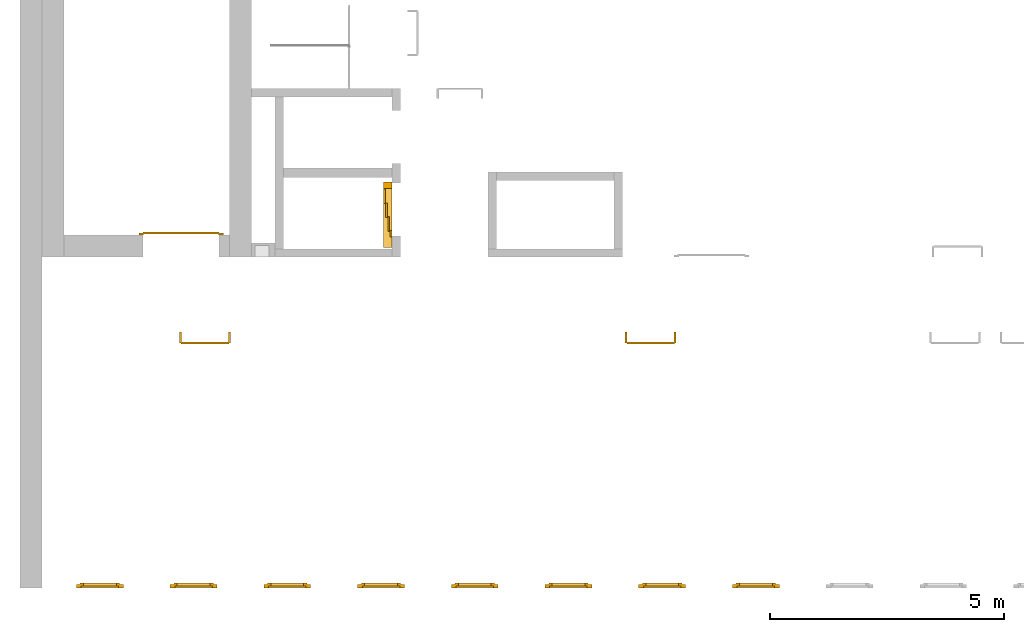
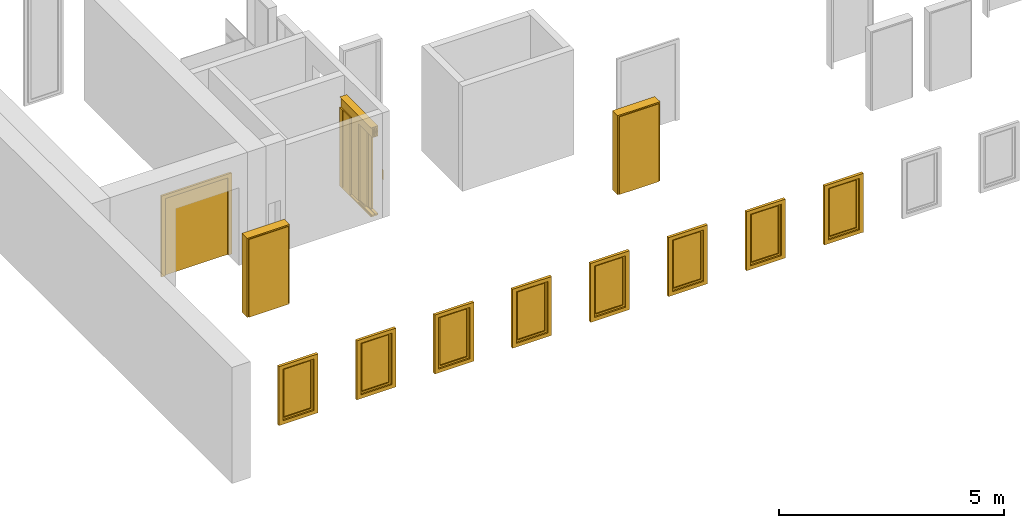
# One storey, part 2 of 5: 8 windows, 4 doors.
"""IFC4 building model written with IfcOpenShell, lengths in metres."""

from ifc_helpers import new_model, entity, si_unit, converted_unit, derived_unit, direction, frame, origin_with_axes, place, context, subcontext, project, spatial, polygons, source, transform, mapped, type_object, element, save


model = new_model("IFC4")

# Units and contexts
model_context = context("Model", 3, precision=1e-05, world=origin_with_axes(), true_north=direction((0.0, 1.0)))
body_context = subcontext(model_context, "Body", "Model", "MODEL_VIEW")
ifc_project = project(units=[si_unit("LENGTHUNIT", "METRE"), si_unit("AREAUNIT", "SQUARE_METRE"), si_unit("VOLUMEUNIT", "CUBIC_METRE"), converted_unit("PLANEANGLEUNIT", "DEGREE", entity("IfcPlaneAngleMeasure", 0.0174532925199433), si_unit("PLANEANGLEUNIT", "RADIAN"), dimensions=[0, 0, 0, 0, 0, 0, 0]), converted_unit("TIMEUNIT", "Year", entity("IfcTimeMeasure", 31557600.0), si_unit("TIMEUNIT", "SECOND"), dimensions=[0, 0, 1, 0, 0, 0, 0]), si_unit("MASSUNIT", "GRAM", prefix="KILO"), si_unit("THERMODYNAMICTEMPERATUREUNIT", "DEGREE_CELSIUS"), si_unit("LUMINOUSINTENSITYUNIT", "LUMEN"), si_unit("ENERGYUNIT", "JOULE", prefix="MEGA"), derived_unit("THERMALCONDUCTANCEUNIT", [(si_unit("POWERUNIT", "WATT"), 1), (si_unit("LENGTHUNIT", "METRE"), -1), (si_unit("THERMODYNAMICTEMPERATUREUNIT", "KELVIN"), -1)]), derived_unit("SPECIFICHEATCAPACITYUNIT", [(si_unit("ENERGYUNIT", "JOULE"), 1), (si_unit("MASSUNIT", "GRAM", prefix="KILO"), -1), (si_unit("THERMODYNAMICTEMPERATUREUNIT", "KELVIN"), -1)]), derived_unit("MASSDENSITYUNIT", [(si_unit("MASSUNIT", "GRAM", prefix="KILO"), 1), (si_unit("VOLUMEUNIT", "CUBIC_METRE"), -1)])], contexts=[model_context])

# Site, building, storey
site_placement = place(None, origin_with_axes())
site = spatial("IfcSite", under=ifc_project, at=site_placement, CompositionType="ELEMENT")
building_placement = place(None, origin_with_axes())
building = spatial("IfcBuilding", under=site, at=building_placement, CompositionType="ELEMENT")
storey_placement = place(None, frame((0.0, 0.0, 7.5), z_axis=(0.0, 0.0, 1.0), x_axis=(1.0, 0.0, 0.0)))
storey = spatial("IfcBuildingStorey", under=building, at=storey_placement, Name="2 OG", CompositionType="ELEMENT", Elevation=7.5)

# Windows
window_type = type_object("IfcWindowType", Name="1-27", PartitioningType="SINGLE_PANEL", PredefinedType="WINDOW")
shared_shape_1 = source(origin_with_axes(), body_context, "Body", "Tessellation", [
    polygons([(-0.5, -0.07, 0.0), (-0.5, 0.0, 0.0), (-0.4, 0.0, 0.1), (-0.4, -0.07, 0.1), (-0.5, -0.07, 1.6), (-0.5, 0.0, 1.6), (-0.4, 0.0, 1.5), (-0.4, -0.07, 1.5)], [[[1, 2, 3, 4]], [[5, 6, 2, 1]], [[2, 6, 7, 3]], [[4, 3, 7, 8]], [[1, 4, 8, 5]], [[8, 7, 6, 5]]], closed=True),
    polygons([(0.5, -0.07, 0.0), (0.5, 0.0, 0.0), (0.5, 0.0, 1.6), (0.5, -0.07, 1.6), (0.4, -0.07, 0.1), (0.4, 0.0, 0.1), (0.4, 0.0, 1.5), (0.4, -0.07, 1.5)], [[[1, 2, 3, 4]], [[5, 6, 2, 1]], [[2, 6, 7, 3]], [[4, 3, 7, 8]], [[1, 4, 8, 5]], [[8, 7, 6, 5]]], closed=True),
    polygons([(-0.5, -0.07, 0.0), (-0.5, 0.0, 0.0), (0.5, 0.0, 0.0), (0.5, -0.07, 0.0), (-0.4, -0.07, 0.1), (-0.4, 0.0, 0.1), (0.0, 0.0, 0.1), (0.4, 0.0, 0.1), (0.4, -0.07, 0.1), (0.0, -0.07, 0.1)], [[[1, 2, 3, 4]], [[5, 6, 2, 1]], [[2, 6, 7, 8, 3]], [[4, 3, 8, 9]], [[1, 4, 9, 10, 5]], [[10, 7, 6, 5]], [[9, 8, 7, 10]]], closed=True),
    polygons([(-0.5, -0.07, 1.6), (-0.5, 0.0, 1.6), (-0.4, 0.0, 1.5), (-0.4, -0.07, 1.5), (0.5, -0.07, 1.6), (0.5, 0.0, 1.6), (0.4, 0.0, 1.5), (0.0, 0.0, 1.5), (0.0, -0.07, 1.5), (0.4, -0.07, 1.5)], [[[1, 2, 3, 4]], [[5, 6, 2, 1]], [[2, 6, 7, 8, 3]], [[4, 3, 8, 9]], [[1, 4, 9, 10, 5]], [[10, 7, 6, 5]], [[9, 8, 7, 10]]], closed=True),
    polygons([(-0.42, 0.0, 0.08), (-0.42, 0.03, 0.08), (-0.35, 0.03, 0.15), (-0.35, 0.0, 0.15), (-0.42, 0.0, 1.52), (-0.42, 0.03, 1.52), (-0.35, 0.03, 1.45), (-0.35, 0.0, 1.45)], [[[1, 2, 3, 4]], [[5, 6, 2, 1]], [[2, 6, 7, 3]], [[4, 3, 7, 8]], [[1, 4, 8, 5]], [[8, 7, 6, 5]]], closed=True),
    polygons([(0.42, 0.0, 0.08), (0.35, 0.0, 0.15), (0.35, 0.03, 0.15), (0.42, 0.03, 0.08), (0.42, 0.0, 1.52), (0.35, 0.0, 1.45), (0.35, 0.03, 1.45), (0.42, 0.03, 1.52)], [[[1, 2, 3, 4]], [[1, 5, 6, 2]], [[2, 6, 7, 3]], [[4, 3, 7, 8]], [[5, 1, 4, 8]], [[6, 5, 8, 7]]], closed=True),
    polygons([(-0.42, 0.0, 0.08), (-0.42, 0.03, 0.08), (0.42, 0.03, 0.08), (0.42, 0.0, 0.08), (-0.35, 0.0, 0.15), (-0.35, 0.03, 0.15), (0.35, 0.03, 0.15), (0.35, 0.0, 0.15)], [[[1, 2, 3, 4]], [[5, 6, 2, 1]], [[2, 6, 7, 3]], [[4, 3, 7, 8]], [[1, 4, 8, 5]], [[8, 7, 6, 5]]], closed=True),
    polygons([(-0.42, 0.0, 1.52), (0.42, 0.0, 1.52), (0.42, 0.03, 1.52), (-0.42, 0.03, 1.52), (-0.35, 0.0, 1.45), (0.35, 0.0, 1.45), (0.35, 0.03, 1.45), (-0.35, 0.03, 1.45)], [[[1, 2, 3, 4]], [[1, 5, 6, 2]], [[2, 6, 7, 3]], [[4, 3, 7, 8]], [[5, 1, 4, 8]], [[6, 5, 8, 7]]], closed=True),
    polygons([(-0.4, -0.03, 0.1), (-0.4, 0.0, 0.1), (-0.35, 0.0, 0.15), (-0.35, -0.03, 0.15), (-0.4, -0.03, 1.5), (-0.4, 0.0, 1.5), (-0.35, 0.0, 1.45), (-0.35, -0.03, 1.45)], [[[1, 2, 3, 4]], [[5, 6, 2, 1]], [[2, 6, 7, 3]], [[4, 3, 7, 8]], [[1, 4, 8, 5]], [[8, 7, 6, 5]]], closed=True),
    polygons([(0.4, -0.03, 0.1), (0.35, -0.03, 0.15), (0.35, 0.0, 0.15), (0.4, 0.0, 0.1), (0.4, -0.03, 1.5), (0.35, -0.03, 1.45), (0.35, 0.0, 1.45), (0.4, 0.0, 1.5)], [[[1, 2, 3, 4]], [[1, 5, 6, 2]], [[2, 6, 7, 3]], [[4, 3, 7, 8]], [[5, 1, 4, 8]], [[6, 5, 8, 7]]], closed=True),
    polygons([(-0.4, -0.03, 0.1), (-0.4, 0.0, 0.1), (0.4, 0.0, 0.1), (0.4, -0.03, 0.1), (-0.35, -0.03, 0.15), (-0.35, 0.0, 0.15), (0.35, 0.0, 0.15), (0.35, -0.03, 0.15)], [[[1, 2, 3, 4]], [[5, 6, 2, 1]], [[2, 6, 7, 3]], [[4, 3, 7, 8]], [[1, 4, 8, 5]], [[8, 7, 6, 5]]], closed=True),
    polygons([(-0.4, -0.03, 1.5), (0.4, -0.03, 1.5), (0.4, 0.0, 1.5), (-0.4, 0.0, 1.5), (-0.35, -0.03, 1.45), (0.35, -0.03, 1.45), (0.35, 0.0, 1.45), (-0.35, 0.0, 1.45)], [[[1, 2, 3, 4]], [[1, 5, 6, 2]], [[2, 6, 7, 3]], [[4, 3, 7, 8]], [[5, 1, 4, 8]], [[6, 5, 8, 7]]], closed=True),
    polygons([(-0.35, -0.00500000000000001, 0.15), (-0.35, 0.00499999999999999, 0.15), (0.35, 0.00499999999999999, 0.15), (0.35, -0.00500000000000001, 0.15), (-0.35, -0.00500000000000001, 1.45), (-0.35, 0.00499999999999999, 1.45), (0.35, 0.00499999999999999, 1.45), (0.35, -0.00500000000000001, 1.45)], [[[1, 2, 3, 4]], [[5, 6, 2, 1]], [[2, 6, 7, 3]], [[4, 3, 7, 8]], [[1, 4, 8, 5]], [[8, 7, 6, 5]]], closed=True),
])
window_1_placement = place(None, frame((26.723, 0.0, 8.5), z_axis=(0.0, 0.0, 1.0), x_axis=(1.0, 0.0, 0.0)))
element("IfcWindow", 1, at=window_1_placement, inside=storey, type_object=window_type, Name="Fenster-001", OverallHeight=1.6, OverallWidth=1.0, context=body_context, shape_type="MappedRepresentation", body=[
    mapped(shared_shape_1, transform((0.5, 0.0700000000000032, 0.0))),
])
window_2_placement = place(None, frame((28.723, 0.0, 8.5), z_axis=(0.0, 0.0, 1.0), x_axis=(1.0, 0.0, 0.0)))
element("IfcWindow", 2, at=window_2_placement, inside=storey, type_object=window_type, Name="Fenster-001", OverallHeight=1.6, OverallWidth=1.0, context=body_context, shape_type="MappedRepresentation", body=[
    mapped(shared_shape_1, transform((0.5, 0.0700000000000029, 0.0))),
])
window_3_placement = place(None, frame((38.723, 0.0, 8.5), z_axis=(0.0, 0.0, 1.0), x_axis=(1.0, 0.0, 0.0)))
element("IfcWindow", 3, at=window_3_placement, inside=storey, type_object=window_type, Name="Fenster-001", OverallHeight=1.6, OverallWidth=1.0, context=body_context, shape_type="MappedRepresentation", body=[
    mapped(shared_shape_1, transform((0.5, 0.0700000000000017, 0.0))),
])
window_4_placement = place(None, frame((24.723, 0.0, 8.5), z_axis=(0.0, 0.0, 1.0), x_axis=(1.0, 0.0, 0.0)))
element("IfcWindow", 4, at=window_4_placement, inside=storey, type_object=window_type, Name="Fenster-001", OverallHeight=1.6, OverallWidth=1.0, context=body_context, shape_type="MappedRepresentation", body=[
    mapped(shared_shape_1, transform((0.5, 0.0700000000000035, 0.0))),
])
window_5_placement = place(None, frame((30.723, 0.0, 8.5), z_axis=(0.0, 0.0, 1.0), x_axis=(1.0, 0.0, 0.0)))
element("IfcWindow", 5, at=window_5_placement, inside=storey, type_object=window_type, Name="Fenster-001", OverallHeight=1.6, OverallWidth=1.0, context=body_context, shape_type="MappedRepresentation", body=[
    mapped(shared_shape_1, transform((0.5, 0.0700000000000027, 0.0))),
])
window_6_placement = place(None, frame((36.723, 0.0, 8.5), z_axis=(0.0, 0.0, 1.0), x_axis=(1.0, 0.0, 0.0)))
element("IfcWindow", 6, at=window_6_placement, inside=storey, type_object=window_type, Name="Fenster-001", OverallHeight=1.6, OverallWidth=1.0, context=body_context, shape_type="MappedRepresentation", body=[
    mapped(shared_shape_1, transform((0.5, 0.0700000000000019, 0.0))),
])
window_7_placement = place(None, frame((32.723, 0.0, 8.5), z_axis=(0.0, 0.0, 1.0), x_axis=(1.0, 0.0, 0.0)))
element("IfcWindow", 7, at=window_7_placement, inside=storey, type_object=window_type, Name="Fenster-001", OverallHeight=1.6, OverallWidth=1.0, context=body_context, shape_type="MappedRepresentation", body=[
    mapped(shared_shape_1, transform((0.5, 0.0700000000000025, 0.0))),
])
window_8_placement = place(None, frame((34.723, 0.0, 8.5), z_axis=(0.0, 0.0, 1.0), x_axis=(1.0, 0.0, 0.0)))
element("IfcWindow", 8, at=window_8_placement, inside=storey, type_object=window_type, Name="Fenster-001", OverallHeight=1.6, OverallWidth=1.0, context=body_context, shape_type="MappedRepresentation", body=[
    mapped(shared_shape_1, transform((0.5, 0.0700000000000023, 0.0))),
])

# Doors
door_type_1 = type_object("IfcDoorType", Name="27", OperationType="SINGLE_SWING_RIGHT", PredefinedType="DOOR")
shared_shape_2 = source(origin_with_axes(), body_context, "Body", "Tessellation", [
    polygons([(0.545, -0.2325, 0.0), (0.545, -0.025, 0.0), (0.545, -0.025, 2.145), (0.545, -0.2325, 2.145), (0.5, -0.2325, 0.0), (0.5, -0.025, 0.0), (0.5, -0.025, 2.1), (0.0551, -0.025, 2.1), (0.0001, -0.025, 2.1), (-0.5, -0.025, 2.1), (-0.5, -0.025, 0.0), (-0.545, -0.025, 0.0), (-0.545, -0.025, 2.145), (-0.545, -0.2325, 2.145), (-0.545, -0.2325, 0.0), (-0.5, -0.2325, 0.0), (-0.5, -0.2325, 2.1), (0.0001, -0.2325, 2.1), (0.0551, -0.2325, 2.1), (0.5, -0.2325, 2.1)], [[[1, 2, 3, 4]], [[5, 6, 2, 1]], [[2, 6, 7, 8, 9, 10, 11, 12, 13, 3]], [[4, 3, 13, 14]], [[1, 4, 14, 15, 16, 17, 18, 19, 20, 5]], [[20, 7, 6, 5]], [[19, 8, 7, 20]], [[18, 9, 8, 19]], [[17, 10, 9, 18]], [[16, 11, 10, 17]], [[15, 12, 11, 16]], [[14, 13, 12, 15]]], closed=True),
    polygons([(0.545, -0.025, 0.0), (0.545, 0.0, 0.0), (0.545, 0.0, 2.145), (0.545, -0.025, 2.145), (0.51, -0.025, 0.0), (0.51, 0.0, 0.0), (0.51, 0.0, 2.11), (0.0451, 0.0, 2.11), (0.0101, 0.0, 2.11), (-0.51, 0.0, 2.11), (-0.51, 0.0, 0.0), (-0.545, 0.0, 0.0), (-0.545, 0.0, 2.145), (-0.545, -0.025, 2.145), (-0.545, -0.025, 0.0), (-0.51, -0.025, 0.0), (-0.51, -0.025, 2.11), (0.0101, -0.025, 2.11), (0.0451, -0.025, 2.11), (0.51, -0.025, 2.11)], [[[1, 2, 3, 4]], [[5, 6, 2, 1]], [[2, 6, 7, 8, 9, 10, 11, 12, 13, 3]], [[4, 3, 13, 14]], [[1, 4, 14, 15, 16, 17, 18, 19, 20, 5]], [[20, 7, 6, 5]], [[19, 8, 7, 20]], [[18, 9, 8, 19]], [[17, 10, 9, 18]], [[16, 11, 10, 17]], [[15, 12, 11, 16]], [[14, 13, 12, 15]]], closed=True),
    polygons([(0.51, 0.015, 0.0), (-0.51, 0.015, 0.0), (-0.51, 0.015, 2.11), (0.51, 0.015, 2.11), (0.51, -0.025, 0.0), (-0.51, -0.025, 0.0), (-0.51, -0.025, 2.11), (0.51, -0.025, 2.11)], [[[1, 2, 3, 4]], [[2, 1, 5, 6]], [[3, 2, 6, 7]], [[4, 3, 7, 8]], [[1, 4, 8, 5]], [[6, 5, 8, 7]]], closed=True),
])
door_1_placement = place(None, frame((37.477, 5.45499994546755, 7.5), z_axis=(0.0, 0.0, 1.0), x_axis=(-1.0, 0.0, 0.0)))
element("IfcDoor", 9, at=door_1_placement, inside=storey, type_object=door_type_1, OverallHeight=2.145, OverallWidth=1.09, context=body_context, shape_type="MappedRepresentation", body=[
    mapped(shared_shape_2, transform((0.5, 0.2325, 0.0))),
])
door_type_2 = type_object("IfcDoorType", OperationType="DOUBLE_DOOR_SINGLE_SWING", PredefinedType="DOOR")
shared_shape_3 = source(origin_with_axes(), body_context, "Body", "Tessellation", [
    polygons([(0.9, 0.0, 0.0), (0.9, 0.03, 0.0), (0.9, 0.03, 2.2), (0.9, 0.0, 2.2), (0.8, 0.0, 0.0), (0.8, 0.03, 0.0), (0.8, 0.03, 2.1), (0.1101, 0.03, 2.1), (0.0001, 0.03, 2.1), (-0.8, 0.03, 2.1), (-0.8, 0.03, 0.0), (-0.9, 0.03, 0.0), (-0.9, 0.03, 2.2), (-0.9, 0.0, 2.2), (-0.9, 0.0, 0.0), (-0.8, 0.0, 0.0), (-0.8, 0.0, 2.1), (0.0001, 0.0, 2.1), (0.1101, 0.0, 2.1), (0.8, 0.0, 2.1)], [[[1, 2, 3, 4]], [[5, 6, 2, 1]], [[2, 6, 7, 8, 9, 10, 11, 12, 13, 3]], [[4, 3, 13, 14]], [[1, 4, 14, 15, 16, 17, 18, 19, 20, 5]], [[20, 7, 6, 5]], [[19, 8, 7, 20]], [[18, 9, 8, 19]], [[17, 10, 9, 18]], [[16, 11, 10, 17]], [[15, 12, 11, 16]], [[14, 13, 12, 15]]], closed=True),
    polygons([(0.9, 0.03, 0.0), (0.9, 0.05, 0.0), (0.9, 0.05, 2.2), (0.9, 0.03, 2.2), (0.81, 0.03, 0.0), (0.81, 0.05, 0.0), (0.81, 0.05, 2.11), (0.1001, 0.05, 2.11), (0.0101, 0.05, 2.11), (-0.81, 0.05, 2.11), (-0.81, 0.05, 0.0), (-0.9, 0.05, 0.0), (-0.9, 0.05, 2.2), (-0.9, 0.03, 2.2), (-0.9, 0.03, 0.0), (-0.81, 0.03, 0.0), (-0.81, 0.03, 2.11), (0.0101, 0.03, 2.11), (0.1001, 0.03, 2.11), (0.81, 0.03, 2.11)], [[[1, 2, 3, 4]], [[5, 6, 2, 1]], [[2, 6, 7, 8, 9, 10, 11, 12, 13, 3]], [[4, 3, 13, 14]], [[1, 4, 14, 15, 16, 17, 18, 19, 20, 5]], [[20, 7, 6, 5]], [[19, 8, 7, 20]], [[18, 9, 8, 19]], [[17, 10, 9, 18]], [[16, 11, 10, 17]], [[15, 12, 11, 16]], [[14, 13, 12, 15]]], closed=True),
    polygons([(0.81, 0.07, 0.0), (0.000499999999999945, 0.07, 0.0), (0.000499999999999945, 0.07, 2.11), (0.81, 0.07, 2.11), (0.81, 0.03, 0.0), (0.000499999999999945, 0.03, 0.0), (0.000499999999999945, 0.03, 2.11), (0.81, 0.03, 2.11)], [[[1, 2, 3, 4]], [[2, 1, 5, 6]], [[3, 2, 6, 7]], [[4, 3, 7, 8]], [[1, 4, 8, 5]], [[6, 5, 8, 7]]], closed=True),
    polygons([(-0.81, 0.07, 0.0), (-0.81, 0.07, 2.11), (-0.000499999999999945, 0.07, 2.11), (-0.000499999999999945, 0.07, 0.0), (-0.81, 0.03, 0.0), (-0.81, 0.03, 2.11), (-0.000499999999999945, 0.03, 2.11), (-0.000499999999999945, 0.03, 0.0)], [[[1, 2, 3, 4]], [[1, 5, 6, 2]], [[2, 6, 7, 3]], [[3, 7, 8, 4]], [[4, 8, 5, 1]], [[8, 7, 6, 5]]], closed=True),
])
door_2_placement = place(None, frame((26.158, 7.52499994546755, 7.5), z_axis=(0.0, 0.0, 1.0), x_axis=(1.0, 0.0, 0.0)))
element("IfcDoor", 10, at=door_2_placement, inside=storey, type_object=door_type_2, OverallHeight=2.11, OverallWidth=1.62, context=body_context, shape_type="MappedRepresentation", body=[
    mapped(shared_shape_3, transform((0.800000000000001, 0.0, 0.0))),
])
door_type_3 = type_object("IfcDoorType", Name="27", OperationType="SINGLE_SWING_LEFT", PredefinedType="DOOR")
shared_shape_4 = source(origin_with_axes(), body_context, "Body", "Tessellation", [
    polygons([(-0.545, -0.2325, 0.0), (-0.545, -0.2325, 2.145), (-0.545, -0.025, 2.145), (-0.545, -0.025, 0.0), (-0.5, -0.2325, 0.0), (-0.5, -0.2325, 2.1), (-0.0551, -0.2325, 2.1), (-0.0001, -0.2325, 2.1), (0.5, -0.2325, 2.1), (0.5, -0.2325, 0.0), (0.545, -0.2325, 0.0), (0.545, -0.2325, 2.145), (0.545, -0.025, 2.145), (0.545, -0.025, 0.0), (0.5, -0.025, 0.0), (0.5, -0.025, 2.1), (-0.0001, -0.025, 2.1), (-0.0551, -0.025, 2.1), (-0.5, -0.025, 2.1), (-0.5, -0.025, 0.0)], [[[1, 2, 3, 4]], [[1, 5, 6, 7, 8, 9, 10, 11, 12, 2]], [[2, 12, 13, 3]], [[4, 3, 13, 14, 15, 16, 17, 18, 19, 20]], [[5, 1, 4, 20]], [[6, 5, 20, 19]], [[7, 6, 19, 18]], [[8, 7, 18, 17]], [[9, 8, 17, 16]], [[10, 9, 16, 15]], [[11, 10, 15, 14]], [[12, 11, 14, 13]]], closed=True),
    polygons([(-0.545, -0.025, 0.0), (-0.545, -0.025, 2.145), (-0.545, 0.0, 2.145), (-0.545, 0.0, 0.0), (-0.51, -0.025, 0.0), (-0.51, -0.025, 2.11), (-0.0451, -0.025, 2.11), (-0.0101, -0.025, 2.11), (0.51, -0.025, 2.11), (0.51, -0.025, 0.0), (0.545, -0.025, 0.0), (0.545, -0.025, 2.145), (0.545, 0.0, 2.145), (0.545, 0.0, 0.0), (0.51, 0.0, 0.0), (0.51, 0.0, 2.11), (-0.0101, 0.0, 2.11), (-0.0451, 0.0, 2.11), (-0.51, 0.0, 2.11), (-0.51, 0.0, 0.0)], [[[1, 2, 3, 4]], [[1, 5, 6, 7, 8, 9, 10, 11, 12, 2]], [[2, 12, 13, 3]], [[4, 3, 13, 14, 15, 16, 17, 18, 19, 20]], [[5, 1, 4, 20]], [[6, 5, 20, 19]], [[7, 6, 19, 18]], [[8, 7, 18, 17]], [[9, 8, 17, 16]], [[10, 9, 16, 15]], [[11, 10, 15, 14]], [[12, 11, 14, 13]]], closed=True),
    polygons([(-0.51, 0.015, 0.0), (-0.51, 0.015, 2.11), (0.51, 0.015, 2.11), (0.51, 0.015, 0.0), (-0.51, -0.025, 0.0), (-0.51, -0.025, 2.11), (0.51, -0.025, 2.11), (0.51, -0.025, 0.0)], [[[1, 2, 3, 4]], [[1, 5, 6, 2]], [[2, 6, 7, 3]], [[3, 7, 8, 4]], [[4, 8, 5, 1]], [[8, 7, 6, 5]]], closed=True),
])
door_3_placement = place(None, frame((27.969, 5.45499994546755, 7.5), z_axis=(0.0, 0.0, 1.0), x_axis=(-1.0, 0.0, 0.0)))
element("IfcDoor", 11, at=door_3_placement, inside=storey, type_object=door_type_3, OverallHeight=2.145, OverallWidth=1.09, context=body_context, shape_type="MappedRepresentation", body=[
    mapped(shared_shape_4, transform((0.5, 0.2325, 0.0))),
])
door_type_4 = type_object("IfcDoorType", Name="27", OperationType="DOUBLE_DOOR_SLIDING", PredefinedType="DOOR")
shared_shape_5 = source(origin_with_axes(), body_context, "Body", "Tessellation", [
    polygons([(-0.808333333333334, 0.135, 2.1), (-0.808333333333334, 0.135, 2.138), (0.585, 0.135, 2.138), (0.585, 0.135, 2.1), (-0.808333333333334, 0.0, 2.1), (-0.808333333333334, 0.0, 2.38), (-0.808333333333334, 0.18, 2.38), (-0.808333333333334, 0.18, 2.377), (-0.808333333333334, 0.003, 2.377), (-0.808333333333334, 0.003, 2.103), (-0.808333333333334, 0.132, 2.103), (-0.808333333333334, 0.132, 2.138), (0.585, 0.132, 2.138), (0.585, 0.132, 2.103), (0.585, 0.00299999999999992, 2.103), (0.585, 0.00299999999999992, 2.377), (0.585, 0.18, 2.377), (0.585, 0.18, 2.38), (0.585, 0.0, 2.38), (0.585, 0.0, 2.1)], [[[1, 2, 3, 4]], [[1, 5, 6, 7, 8, 9, 10, 11, 12, 2]], [[2, 12, 13, 3]], [[4, 3, 13, 14, 15, 16, 17, 18, 19, 20]], [[5, 1, 4, 20]], [[6, 5, 20, 19]], [[7, 6, 19, 18]], [[8, 7, 18, 17]], [[9, 8, 17, 16]], [[10, 9, 16, 15]], [[11, 10, 15, 14]], [[12, 11, 14, 13]]], closed=True),
    polygons([(-0.808333333333334, 0.05, 2.103), (-0.808333333333334, 0.055, 2.103), (0.585, 0.0549999999999999, 2.103), (0.585, 0.0499999999999999, 2.103), (-0.808333333333334, 0.05, 2.34), (-0.808333333333334, 0.055, 2.34), (0.585, 0.0549999999999999, 2.34), (0.585, 0.0499999999999999, 2.34)], [[[1, 2, 3, 4]], [[1, 5, 6, 2]], [[2, 6, 7, 3]], [[4, 3, 7, 8]], [[5, 1, 4, 8]], [[6, 5, 8, 7]]], closed=True),
    polygons([(-0.808333333333334, 0.05, 2.33), (-0.808333333333334, 0.04, 2.33), (0.585, 0.0399999999999999, 2.33), (0.585, 0.0499999999999999, 2.33), (-0.808333333333334, 0.05, 2.27), (-0.808333333333334, 0.04, 2.27), (0.585, 0.0399999999999999, 2.27), (0.585, 0.0499999999999999, 2.27)], [[[1, 2, 3, 4]], [[1, 5, 6, 2]], [[2, 6, 7, 3]], [[4, 3, 7, 8]], [[5, 1, 4, 8]], [[6, 5, 8, 7]]], closed=True),
    polygons([(-0.808333333333334, 0.05, 2.2), (-0.808333333333334, 0.04, 2.2), (0.585, 0.0399999999999999, 2.2), (0.585, 0.0499999999999999, 2.2), (-0.808333333333334, 0.05, 2.16), (-0.808333333333334, 0.04, 2.16), (0.585, 0.0399999999999999, 2.16), (0.585, 0.0499999999999999, 2.16)], [[[1, 2, 3, 4]], [[1, 5, 6, 2]], [[2, 6, 7, 3]], [[4, 3, 7, 8]], [[5, 1, 4, 8]], [[6, 5, 8, 7]]], closed=True),
    polygons([(-0.808333333333334, 0.05, 2.27), (-0.808333333333334, 0.03, 2.27), (0.585, 0.0299999999999999, 2.27), (0.585, 0.0499999999999999, 2.27), (-0.808333333333334, 0.05, 2.2), (-0.808333333333334, 0.03, 2.2), (0.585, 0.0299999999999999, 2.2), (0.585, 0.0499999999999999, 2.2)], [[[1, 2, 3, 4]], [[1, 5, 6, 2]], [[2, 6, 7, 3]], [[4, 3, 7, 8]], [[5, 1, 4, 8]], [[6, 5, 8, 7]]], closed=True),
    polygons([(-0.808333333333334, 0.095, 2.103), (-0.808333333333334, 0.1, 2.103), (0.585, 0.0999999999999999, 2.103), (0.585, 0.0949999999999999, 2.103), (-0.808333333333334, 0.095, 2.34), (-0.808333333333334, 0.1, 2.34), (0.585, 0.0999999999999999, 2.34), (0.585, 0.0949999999999999, 2.34)], [[[1, 2, 3, 4]], [[1, 5, 6, 2]], [[2, 6, 7, 3]], [[4, 3, 7, 8]], [[5, 1, 4, 8]], [[6, 5, 8, 7]]], closed=True),
    polygons([(-0.808333333333334, 0.095, 2.33), (-0.808333333333334, 0.085, 2.33), (0.585, 0.0849999999999999, 2.33), (0.585, 0.0949999999999999, 2.33), (-0.808333333333334, 0.095, 2.27), (-0.808333333333334, 0.085, 2.27), (0.585, 0.0849999999999999, 2.27), (0.585, 0.0949999999999999, 2.27)], [[[1, 2, 3, 4]], [[1, 5, 6, 2]], [[2, 6, 7, 3]], [[4, 3, 7, 8]], [[5, 1, 4, 8]], [[6, 5, 8, 7]]], closed=True),
    polygons([(-0.808333333333334, 0.095, 2.2), (-0.808333333333334, 0.085, 2.2), (0.585, 0.0849999999999999, 2.2), (0.585, 0.0949999999999999, 2.2), (-0.808333333333334, 0.095, 2.16), (-0.808333333333334, 0.085, 2.16), (0.585, 0.0849999999999999, 2.16), (0.585, 0.0949999999999999, 2.16)], [[[1, 2, 3, 4]], [[1, 5, 6, 2]], [[2, 6, 7, 3]], [[4, 3, 7, 8]], [[5, 1, 4, 8]], [[6, 5, 8, 7]]], closed=True),
    polygons([(-0.808333333333334, 0.095, 2.27), (-0.808333333333334, 0.075, 2.27), (0.585, 0.0749999999999999, 2.27), (0.585, 0.0949999999999999, 2.27), (-0.808333333333334, 0.095, 2.2), (-0.808333333333334, 0.075, 2.2), (0.585, 0.0749999999999999, 2.2), (0.585, 0.0949999999999999, 2.2)], [[[1, 2, 3, 4]], [[1, 5, 6, 2]], [[2, 6, 7, 3]], [[4, 3, 7, 8]], [[5, 1, 4, 8]], [[6, 5, 8, 7]]], closed=True),
    polygons([(-0.808333333333334, 0.14, 2.103), (-0.808333333333334, 0.145, 2.103), (0.585, 0.145, 2.103), (0.585, 0.14, 2.103), (-0.808333333333334, 0.14, 2.34), (-0.808333333333334, 0.145, 2.34), (0.585, 0.145, 2.34), (0.585, 0.14, 2.34)], [[[1, 2, 3, 4]], [[1, 5, 6, 2]], [[2, 6, 7, 3]], [[4, 3, 7, 8]], [[5, 1, 4, 8]], [[6, 5, 8, 7]]], closed=True),
    polygons([(-0.808333333333334, 0.14, 2.33), (-0.808333333333334, 0.13, 2.33), (0.585, 0.13, 2.33), (0.585, 0.14, 2.33), (-0.808333333333334, 0.14, 2.27), (-0.808333333333334, 0.13, 2.27), (0.585, 0.13, 2.27), (0.585, 0.14, 2.27)], [[[1, 2, 3, 4]], [[1, 5, 6, 2]], [[2, 6, 7, 3]], [[4, 3, 7, 8]], [[5, 1, 4, 8]], [[6, 5, 8, 7]]], closed=True),
    polygons([(-0.808333333333334, 0.14, 2.2), (-0.808333333333334, 0.13, 2.2), (0.585, 0.13, 2.2), (0.585, 0.14, 2.2), (-0.808333333333334, 0.14, 2.16), (-0.808333333333334, 0.13, 2.16), (0.585, 0.13, 2.16), (0.585, 0.14, 2.16)], [[[1, 2, 3, 4]], [[1, 5, 6, 2]], [[2, 6, 7, 3]], [[4, 3, 7, 8]], [[5, 1, 4, 8]], [[6, 5, 8, 7]]], closed=True),
    polygons([(-0.808333333333334, 0.14, 2.27), (-0.808333333333334, 0.12, 2.27), (0.585, 0.12, 2.27), (0.585, 0.14, 2.27), (-0.808333333333334, 0.14, 2.2), (-0.808333333333334, 0.12, 2.2), (0.585, 0.12, 2.2), (0.585, 0.14, 2.2)], [[[1, 2, 3, 4]], [[1, 5, 6, 2]], [[2, 6, 7, 3]], [[4, 3, 7, 8]], [[5, 1, 4, 8]], [[6, 5, 8, 7]]], closed=True),
    polygons([(-0.808333333333334, 0.0, 0.0), (-0.808333333333334, 0.0, -0.04), (0.585, 0.0, -0.04), (0.585, 0.0, 0.0), (-0.808333333333334, 0.065, 0.0), (-0.808333333333334, 0.065, -0.01), (-0.808333333333334, 0.075, -0.01), (-0.808333333333334, 0.075, 0.0), (-0.808333333333334, 0.11, 0.0), (-0.808333333333334, 0.11, -0.01), (-0.808333333333334, 0.12, -0.01), (-0.808333333333334, 0.12, 0.0), (-0.808333333333334, 0.155, 0.0), (-0.808333333333334, 0.155, -0.01), (-0.808333333333334, 0.165, -0.01), (-0.808333333333334, 0.165, 0.0), (-0.808333333333334, 0.18, 0.0), (-0.808333333333334, 0.18, -0.04), (0.585, 0.18, -0.04), (0.585, 0.18, 0.0), (0.585, 0.165, 0.0), (0.585, 0.165, -0.01), (0.585, 0.155, -0.01), (0.585, 0.155, 0.0), (0.585, 0.12, 0.0), (0.585, 0.12, -0.01), (0.585, 0.11, -0.01), (0.585, 0.11, 0.0), (0.585, 0.0749999999999999, 0.0), (0.585, 0.0749999999999999, -0.01), (0.585, 0.0649999999999999, -0.01), (0.585, 0.0649999999999999, 0.0)], [[[1, 2, 3, 4]], [[1, 5, 6, 7, 8, 9, 10, 11, 12, 13, 14, 15, 16, 17, 18, 2]], [[2, 18, 19, 3]], [[4, 3, 19, 20, 21, 22, 23, 24, 25, 26, 27, 28, 29, 30, 31, 32]], [[5, 1, 4, 32]], [[6, 5, 32, 31]], [[7, 6, 31, 30]], [[8, 7, 30, 29]], [[9, 8, 29, 28]], [[10, 9, 28, 27]], [[11, 10, 27, 26]], [[12, 11, 26, 25]], [[13, 12, 25, 24]], [[14, 13, 24, 23]], [[15, 14, 23, 22]], [[16, 15, 22, 21]], [[17, 16, 21, 20]], [[18, 17, 20, 19]]], closed=True),
    polygons([(-0.45, 0.0, 0.0), (-0.45, 0.045, 0.0), (-0.45, 0.0449999999999999, 2.1), (-0.45, 0.0, 2.1), (-0.585, 0.0, 0.0), (-0.585, 0.045, 0.0), (-0.585, 0.0449999999999999, 2.1), (-0.585, 0.0, 2.1)], [[[1, 2, 3, 4]], [[1, 5, 6, 2]], [[2, 6, 7, 3]], [[4, 3, 7, 8]], [[5, 1, 4, 8]], [[6, 5, 8, 7]]], closed=True),
    polygons([(0.585, 0.0, 0.0), (0.585, 0.18, 0.0), (0.585, 0.18, 2.1), (0.585, 0.0, 2.1), (0.45, 0.0, 0.0), (0.45, 0.18, 0.0), (0.45, 0.18, 2.1), (0.45, 0.0, 2.1)], [[[1, 2, 3, 4]], [[1, 5, 6, 2]], [[2, 6, 7, 3]], [[4, 3, 7, 8]], [[5, 1, 4, 8]], [[6, 5, 8, 7]]], closed=True),
    polygons([(-0.745, -0.18, 0.8), (-0.665, -0.18, 0.8), (-0.665, -0.183, 0.8), (-0.745, -0.183, 0.8), (-0.745, -0.18, 1.06), (-0.665, -0.18, 1.06), (-0.735, -0.18, 1.03), (-0.735, -0.18, 0.94), (-0.675, -0.18, 0.94), (-0.675, -0.18, 1.03), (-0.715, -0.18, 0.84), (-0.695, -0.18, 0.84), (-0.695, -0.18, 0.86), (-0.715, -0.18, 0.86), (-0.715, -0.18, 0.88), (-0.695, -0.18, 0.88), (-0.695, -0.18, 0.9), (-0.715, -0.18, 0.9), (-0.665, -0.183, 1.06), (-0.745, -0.183, 1.06), (-0.735, -0.183, 1.03), (-0.675, -0.183, 1.03), (-0.675, -0.183, 0.94), (-0.735, -0.183, 0.94), (-0.715, -0.183, 0.84), (-0.715, -0.183, 0.86), (-0.695, -0.183, 0.86), (-0.695, -0.183, 0.84), (-0.715, -0.183, 0.88), (-0.715, -0.183, 0.9), (-0.695, -0.183, 0.9), (-0.695, -0.183, 0.88)], [[[1, 2, 3, 4]], [[1, 5, 6, 2], [7, 8, 9, 10], [11, 12, 13, 14], [15, 16, 17, 18]], [[2, 6, 19, 3]], [[4, 3, 19, 20], [21, 22, 23, 24], [25, 26, 27, 28], [29, 30, 31, 32]], [[5, 1, 4, 20]], [[6, 5, 20, 19]], [[8, 7, 21, 24]], [[9, 8, 24, 23]], [[10, 9, 23, 22]], [[7, 10, 22, 21]], [[12, 11, 25, 28]], [[13, 12, 28, 27]], [[14, 13, 27, 26]], [[11, 14, 26, 25]], [[16, 15, 29, 32]], [[17, 16, 32, 31]], [[18, 17, 31, 30]], [[15, 18, 30, 29]]], closed=True),
    polygons([(-0.735, -0.18, 0.94), (-0.675, -0.18, 0.94), (-0.675, -0.1825, 0.94), (-0.735, -0.1825, 0.94), (-0.735, -0.18, 1.03), (-0.675, -0.18, 1.03), (-0.675, -0.1825, 1.03), (-0.735, -0.1825, 1.03)], [[[1, 2, 3, 4]], [[1, 5, 6, 2]], [[2, 6, 7, 3]], [[4, 3, 7, 8]], [[5, 1, 4, 8]], [[6, 5, 8, 7]]], closed=True),
    polygons([(-0.721, -0.183, 1.005), (-0.715, -0.183, 1.021), (-0.709, -0.183, 1.005)], [[[1, 2, 3]]], closed=False),
    polygons([(-0.695, -0.183, 1.005), (-0.701, -0.183, 1.021), (-0.689, -0.183, 1.021)], [[[1, 2, 3]]], closed=False),
    polygons([(-0.707727272727273, -0.1835, 0.982), (-0.707727272727273, -0.1835, 0.971636363636364), (-0.709090909090909, -0.1835, 0.970272727272727), (-0.710454545454546, -0.1835, 0.971636363636364), (-0.710454545454546, -0.1835, 0.982), (-0.709090909090909, -0.1835, 0.983363636363636)], [[[1, 2, 3, 4, 5, 6]]], closed=False),
    polygons([(-0.707727272727273, -0.1835, 0.968363636363636), (-0.707727272727273, -0.1835, 0.958), (-0.709090909090909, -0.1835, 0.956636363636364), (-0.710454545454546, -0.1835, 0.958), (-0.710454545454546, -0.1835, 0.968363636363636), (-0.709090909090909, -0.1835, 0.969727272727273)], [[[1, 2, 3, 4, 5, 6]]], closed=False),
    polygons([(-0.688909090909091, -0.1835, 0.982272727272727), (-0.699272727272727, -0.1835, 0.982272727272727), (-0.700636363636364, -0.1835, 0.983636363636364), (-0.699272727272727, -0.1835, 0.985), (-0.688909090909091, -0.1835, 0.985), (-0.687545454545455, -0.1835, 0.983636363636364)], [[[1, 2, 3, 4, 5, 6]]], closed=False),
    polygons([(-0.685909090909091, -0.1835, 0.982), (-0.685909090909091, -0.1835, 0.971636363636364), (-0.687272727272727, -0.1835, 0.970272727272727), (-0.688636363636364, -0.1835, 0.971636363636364), (-0.688636363636364, -0.1835, 0.982), (-0.687272727272727, -0.1835, 0.983363636363636)], [[[1, 2, 3, 4, 5, 6]]], closed=False),
    polygons([(-0.688909090909091, -0.1835, 0.968636363636364), (-0.699272727272727, -0.1835, 0.968636363636364), (-0.700636363636364, -0.1835, 0.97), (-0.699272727272727, -0.1835, 0.971363636363636), (-0.688909090909091, -0.1835, 0.971363636363636), (-0.687545454545455, -0.1835, 0.97)], [[[1, 2, 3, 4, 5, 6]]], closed=False),
    polygons([(-0.699545454545455, -0.1835, 0.968363636363636), (-0.699545454545455, -0.1835, 0.958), (-0.700909090909091, -0.1835, 0.956636363636364), (-0.702272727272727, -0.1835, 0.958), (-0.702272727272727, -0.1835, 0.968363636363636), (-0.700909090909091, -0.1835, 0.969727272727273)], [[[1, 2, 3, 4, 5, 6]]], closed=False),
    polygons([(-0.688909090909091, -0.1835, 0.955), (-0.699272727272727, -0.1835, 0.955), (-0.700636363636364, -0.1835, 0.956363636363636), (-0.699272727272727, -0.1835, 0.957727272727273), (-0.688909090909091, -0.1835, 0.957727272727273), (-0.687545454545455, -0.1835, 0.956363636363636)], [[[1, 2, 3, 4, 5, 6]]], closed=False),
    polygons([(-0.695, -0.18, 0.84), (-0.715, -0.18, 0.84), (-0.715, -0.18, 0.86), (-0.695, -0.18, 0.86), (-0.694999999905229, -0.1815, 0.839999999610484), (-0.715000000389516, -0.1815, 0.839999999610484), (-0.715000000389516, -0.1815, 0.860000000094772), (-0.694999999905229, -0.1815, 0.860000000094772), (-0.696400000320971, -0.182900000415742, 0.841400000026226), (-0.713599999973774, -0.182900000415742, 0.841400000026226), (-0.713599999973774, -0.182900000415742, 0.858599999679029), (-0.696400000320971, -0.182900000415742, 0.858599999679029)], [[[1, 2, 3, 4]], [[2, 1, 5, 6]], [[3, 2, 6, 7]], [[4, 3, 7, 8]], [[1, 4, 8, 5]], [[6, 5, 9, 10]], [[7, 6, 10, 11]], [[8, 7, 11, 12]], [[5, 8, 12, 9]], [[11, 10, 9, 12]]], closed=True),
    polygons([(-0.7, -0.183, 0.855), (-0.705, -0.183, 0.844), (-0.71, -0.183, 0.855)], [[[1, 2, 3]]], closed=False),
    polygons([(-0.695, -0.18, 0.88), (-0.715, -0.18, 0.88), (-0.715, -0.18, 0.9), (-0.695, -0.18, 0.9), (-0.694999999905229, -0.1815, 0.879999999610484), (-0.715000000389516, -0.1815, 0.879999999610484), (-0.715000000389516, -0.1815, 0.900000000094772), (-0.694999999905229, -0.1815, 0.900000000094772), (-0.696400000320971, -0.182900000415742, 0.881400000026226), (-0.713599999973774, -0.182900000415742, 0.881400000026226), (-0.713599999973774, -0.182900000415742, 0.898599999679029), (-0.696400000320971, -0.182900000415742, 0.898599999679029)], [[[1, 2, 3, 4]], [[2, 1, 5, 6]], [[3, 2, 6, 7]], [[4, 3, 7, 8]], [[1, 4, 8, 5]], [[6, 5, 9, 10]], [[7, 6, 10, 11]], [[8, 7, 11, 12]], [[5, 8, 12, 9]], [[11, 10, 9, 12]]], closed=True),
    polygons([(-0.7, -0.183, 0.885), (-0.71, -0.183, 0.885), (-0.705, -0.183, 0.896)], [[[1, 2, 3]]], closed=False),
    polygons([(0.126666666666667, 0.14, 0.003), (0.126666666666667, 0.18, 0.003), (0.445, 0.18, 0.003), (0.445, 0.14, 0.003), (0.126666666666667, 0.14, 2.1), (0.126666666666667, 0.18, 2.1), (0.445, 0.18, 2.1), (0.445, 0.14, 2.1)], [[[1, 2, 3, 4]], [[5, 6, 2, 1]], [[2, 6, 7, 3]], [[4, 3, 7, 8]], [[1, 4, 8, 5]], [[8, 7, 6, 5]]], closed=True),
    polygons([(-0.171666666666667, 0.095, 0.003), (-0.171666666666667, 0.135, 0.003), (0.146666666666667, 0.135, 0.003), (0.146666666666667, 0.095, 0.003), (-0.171666666666667, 0.095, 2.1), (-0.171666666666667, 0.135, 2.1), (0.146666666666667, 0.135, 2.1), (0.146666666666667, 0.095, 2.1)], [[[1, 2, 3, 4]], [[5, 6, 2, 1]], [[2, 6, 7, 3]], [[4, 3, 7, 8]], [[1, 4, 8, 5]], [[8, 7, 6, 5]]], closed=True),
    polygons([(-0.47, 0.05, 0.003), (-0.47, 0.09, 0.003), (-0.151666666666667, 0.09, 0.003), (-0.151666666666667, 0.05, 0.003), (-0.47, 0.05, 2.1), (-0.47, 0.09, 2.1), (-0.151666666666667, 0.09, 2.1), (-0.151666666666667, 0.05, 2.1)], [[[1, 2, 3, 4]], [[5, 6, 2, 1]], [[2, 6, 7, 3]], [[4, 3, 7, 8]], [[1, 4, 8, 5]], [[8, 7, 6, 5]]], closed=True),
])
door_4_placement = place(None, frame((31.638, 7.61999994546756, 7.5), z_axis=(0.0, 0.0, 1.0), x_axis=(0.0, 1.0, 0.0)))
element("IfcDoor", 12, at=door_4_placement, inside=storey, type_object=door_type_4, OverallHeight=2.25, OverallWidth=1.13, context=body_context, shape_type="MappedRepresentation", body=[
    mapped(shared_shape_5, transform((0.450000000000001, 0.18, 0.0))),
])

save(model, "model.ifc")
